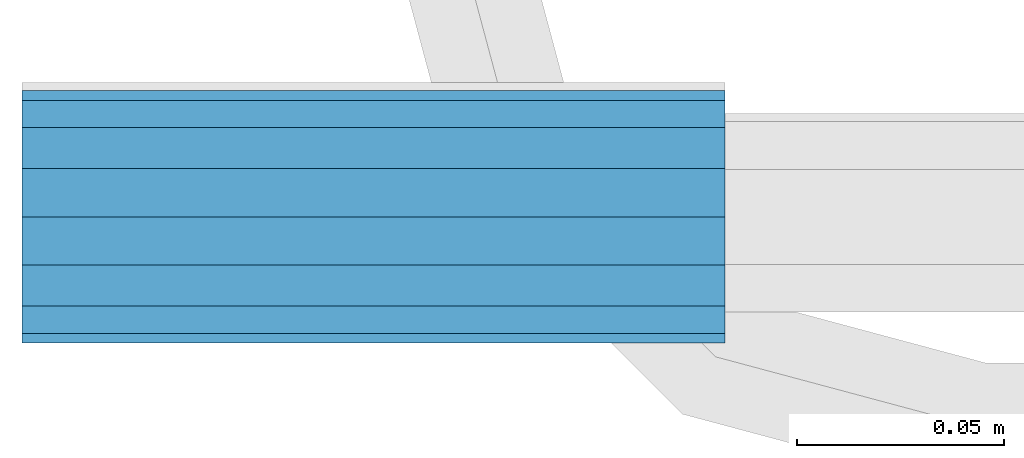
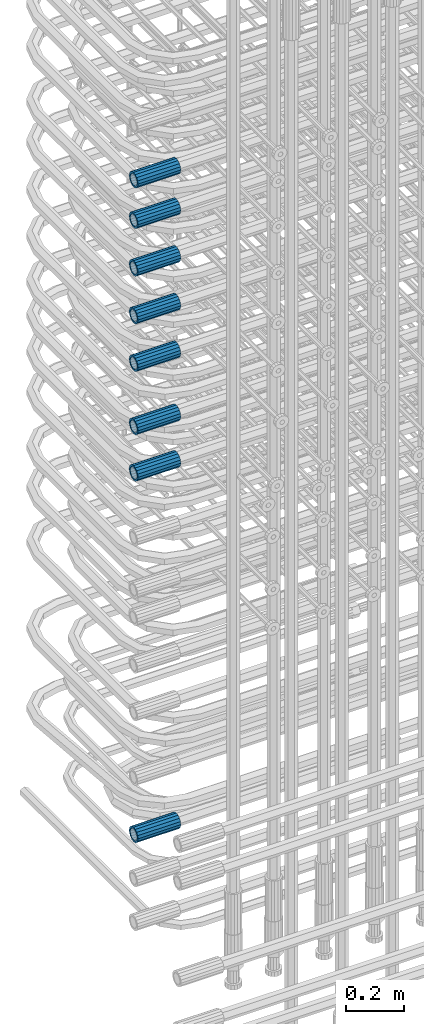
# One storey, part 30 of 177: 8 beams.
"""IFC2X3 building model written with IfcOpenShell, lengths in millimetres."""

import ifcopenshell
import ifcopenshell.guid

model = None  # the IFC model being written
_history = None  # IfcOwnerHistory: only IFC2X3 demands one
_inside = {}  # id of a spatial element -> (the spatial element, [elements in it])
_under = {}  # id of a project, library or spatial element -> (it, [spatial elements below it])
_declared = {}  # id of a project -> (the project, [libraries it declares])
_typed = {}  # id of a type object -> (the type object, [elements of that type])
_made_of = {}  # id of a material, layer set ... -> (it, [elements and type objects made of it])


def new_model(schema):
    """Start an empty IFC model of exactly this schema.

    Asked for "IFC4X3", IfcOpenShell would pick the latest addendum, in which some entities
    have other attributes; the version numbers below select the first issue.
    IFC2X3 requires an IfcOwnerHistory on every rooted entity: one is made here for all.
    """
    global model, _history
    if schema == "IFC4X3":
        model = ifcopenshell.file(schema_version=(4, 3, 0, 0))
    else:
        model = ifcopenshell.file(schema=schema)
    _inside.clear()
    _under.clear()
    _declared.clear()
    _typed.clear()
    _made_of.clear()
    _history = None
    if model.schema == "IFC2X3":
        org = make("IfcOrganization", Name="unknown")
        user = make(
            "IfcPersonAndOrganization",
            ThePerson=make("IfcPerson", FamilyName="unknown"),
            TheOrganization=org,
        )
        app = make(
            "IfcApplication",
            ApplicationDeveloper=org,
            Version="unknown",
            ApplicationFullName="unknown",
            ApplicationIdentifier="unknown",
        )
        _history = make(
            "IfcOwnerHistory",
            OwningUser=user,
            OwningApplication=app,
            ChangeAction="ADDED",
            CreationDate=0,
        )
    return model


def make(cls, **values):
    """One entity of the class cls with the attributes given. An attribute that is None is left unset."""
    return model.create_entity(
        cls, **{name: value for name, value in values.items() if value is not None}
    )


def rooted(cls, **values):
    """An entity with a GlobalId (a new one), such as an element, a storey or a relation."""
    return make(cls, GlobalId=ifcopenshell.guid.new(), OwnerHistory=_history, **values)


def si_unit(unit_type, name, prefix=None):
    """IfcSIUnit, for example si_unit("LENGTHUNIT", "METRE", prefix="MILLI")."""
    return make("IfcSIUnit", UnitType=unit_type, Prefix=prefix, Name=name)


def assignment(units):
    """IfcUnitAssignment: the units of a project."""
    return None if units is None else make("IfcUnitAssignment", Units=units)


def point(xyz):
    """IfcCartesianPoint."""
    return None if xyz is None else make("IfcCartesianPoint", Coordinates=xyz)


def direction(xyz):
    """IfcDirection."""
    return None if xyz is None else make("IfcDirection", DirectionRatios=xyz)


def frame(location, z_axis=None, x_axis=None):
    """IfcAxis2Placement3D, a coordinate frame: its origin and axes. An axis left out is left unset."""
    return make(
        "IfcAxis2Placement3D",
        Location=point(location),
        Axis=direction(z_axis),
        RefDirection=direction(x_axis),
    )


def origin_with_axes():
    """The frame at (0, 0, 0) with the z axis (0, 0, 1) and the x axis (1, 0, 0) written out."""
    return frame((0.0, 0.0, 0.0), z_axis=(0.0, 0.0, 1.0), x_axis=(1.0, 0.0, 0.0))


def place(relative_to, where):
    """IfcLocalPlacement: puts the frame where relative to a parent placement (None: the world)."""
    return make(
        "IfcLocalPlacement", PlacementRelTo=relative_to, RelativePlacement=where
    )


def context(
    kind, dimensions, precision=None, world=None, true_north=None, identifier=None
):
    """IfcGeometricRepresentationContext, for example the 3D "Model" context."""
    return make(
        "IfcGeometricRepresentationContext",
        ContextIdentifier=identifier,
        ContextType=kind,
        CoordinateSpaceDimension=dimensions,
        Precision=precision,
        WorldCoordinateSystem=world,
        TrueNorth=true_north,
    )


def subcontext(parent, identifier, kind, view, scale=None):
    """IfcGeometricRepresentationSubContext, for example "Body" below "Model"."""
    return make(
        "IfcGeometricRepresentationSubContext",
        ContextIdentifier=identifier,
        ContextType=kind,
        ParentContext=parent,
        TargetScale=scale,
        TargetView=view,
    )


def project(units=None, contexts=None):
    """IfcProject with its units and contexts."""
    return rooted(
        "IfcProject",
        Name="project",
        RepresentationContexts=contexts,
        UnitsInContext=assignment(units),
    )


def spatial(cls, under=None, at=None, **own):
    """A site, building, storey or space (cls), placed at a placement, below another one or the project."""
    s = rooted(cls, ObjectPlacement=at, **own)
    if under is not None:
        _under.setdefault(under.id(), (under, []))[1].append(s)
    return s


def faces_of(points, faces, orient=None, outer=None):
    """IfcFace entities. A face is a list of loops; a loop is a list of indices into points, from 0.

    orient and outer hold one flag for each loop. By default every Orientation is true, the
    first loop of a face is its IfcFaceOuterBound and the others are IfcFaceBound.
    """
    made = []
    for i, loops in enumerate(faces):
        bounds = []
        for j, loop in enumerate(loops):
            is_outer = j == 0 if outer is None else outer[i][j]
            bounds.append(
                make(
                    "IfcFaceOuterBound" if is_outer else "IfcFaceBound",
                    Bound=make("IfcPolyLoop", Polygon=[points[k] for k in loop]),
                    Orientation=True if orient is None else orient[i][j],
                )
            )
        made.append(make("IfcFace", Bounds=bounds))
    return made


def faceted_brep(points, faces, orient=None, outer=None, voids=None):
    """IfcFacetedBrep: a solid bounded by flat faces; with voids (closed shells), ...WithVoids."""
    shared = [point(p) for p in points]
    hull = make("IfcClosedShell", CfsFaces=faces_of(shared, faces, orient, outer))
    if voids is None:
        return make("IfcFacetedBrep", Outer=hull)
    return make(
        "IfcFacetedBrepWithVoids",
        Outer=hull,
        Voids=[
            make(cls, CfsFaces=faces_of(shared, fs, o, b)) for cls, fs, o, b in voids
        ],
    )


def shape(context_of_items, identifier, shape_type, items):
    """IfcShapeRepresentation: the items that make up one representation, for example the "Body"."""
    return make(
        "IfcShapeRepresentation",
        ContextOfItems=context_of_items,
        RepresentationIdentifier=identifier,
        RepresentationType=shape_type,
        Items=items,
    )


def material(Name=None, Category=None):
    """IfcMaterial."""
    return make("IfcMaterial", Name=Name, Category=Category)


def made_of(thing, what):
    """Note that an element or type object is made of a material, layer set ...; save() writes the relation."""
    if what is not None:
        _made_of.setdefault(what.id(), (what, []))[1].append(thing)
    return thing


def type_object(cls, material=None, **own):
    """A type object (cls), such as IfcWallType, which elements share."""
    return made_of(rooted(cls, **own), material)


def element(
    cls,
    number,
    at=None,
    inside=None,
    cuts=None,
    type_object=None,
    material=None,
    context=None,
    identifier="Body",
    shape_type=None,
    held_by="IfcProductDefinitionShape",
    body=None,
    shapes=None,
    **own,
):
    """One element of the class cls, such as IfcWall. Its Tag is "e" and its number.

    at: its placement. inside: the storey or other place that contains it. cuts: it is an
    opening in that element (IfcRelVoidsElement). A single representation is given by context,
    identifier, shape_type and body (its items); several are given by shapes. held_by: the class
    of the entity that holds the representations. save() writes the other relations.
    """
    e = rooted(cls, Tag="e%d" % number, ObjectPlacement=at, **own)
    if body is not None:
        shapes = [shape(context, identifier, shape_type, body)]
    if shapes is not None:
        e.Representation = make(held_by, Representations=shapes)
    if inside is not None:
        _inside.setdefault(inside.id(), (inside, []))[1].append(e)
    if cuts is not None:
        rooted(
            "IfcRelVoidsElement", RelatingBuildingElement=cuts, RelatedOpeningElement=e
        )
    if type_object is not None:
        _typed.setdefault(type_object.id(), (type_object, []))[1].append(e)
    return made_of(e, material)


def aggregate(whole, parts):
    """IfcRelAggregates: a whole, such as a stair, and the parts it consists of."""
    return rooted("IfcRelAggregates", RelatingObject=whole, RelatedObjects=parts)


def save(model, path):
    """Write the relations noted so far, then the file.

    IfcRelAggregates (storeys below a building ...), IfcRelContainedInSpatialStructure (elements
    in a storey), IfcRelDefinesByType, IfcRelAssociatesMaterial and IfcRelDeclares: one each for
    every whole, place, type object, material and project.
    """
    for whole, parts in _under.values():
        aggregate(whole, parts)
    for where, things in _inside.values():
        rooted(
            "IfcRelContainedInSpatialStructure",
            RelatedElements=things,
            RelatingStructure=where,
        )
    for kind, things in _typed.values():
        rooted("IfcRelDefinesByType", RelatedObjects=things, RelatingType=kind)
    for what, things in _made_of.values():
        rooted("IfcRelAssociatesMaterial", RelatedObjects=things, RelatingMaterial=what)
    for by, libraries in _declared.values():
        rooted("IfcRelDeclares", RelatingContext=by, RelatedDefinitions=libraries)
    model.write(path)


model = new_model("IFC2X3")

# Units and contexts
model_context_1 = context("Model", 3, precision=1e-05, world=origin_with_axes())
model_context_2 = context("Model", 3, precision=1e-05, world=origin_with_axes())
body_context = subcontext(model_context_2, "Body", "Model", "MODEL_VIEW")
ifc_project = project(units=[si_unit("LENGTHUNIT", "METRE", prefix="MILLI"), si_unit("AREAUNIT", "SQUARE_METRE"), si_unit("VOLUMEUNIT", "CUBIC_METRE"), si_unit("MASSUNIT", "GRAM", prefix="KILO"), si_unit("TIMEUNIT", "SECOND"), si_unit("PLANEANGLEUNIT", "RADIAN"), si_unit("SOLIDANGLEUNIT", "STERADIAN"), si_unit("THERMODYNAMICTEMPERATUREUNIT", "DEGREE_CELSIUS"), si_unit("LUMINOUSINTENSITYUNIT", "LUMEN")], contexts=[model_context_1])

# Site, building, storey
site_placement = place(None, origin_with_axes())
site = spatial("IfcSite", under=ifc_project, at=site_placement, CompositionType="ELEMENT")
building_placement = place(site_placement, origin_with_axes())
building = spatial("IfcBuilding", under=site, at=building_placement, Name="Undefined", CompositionType="ELEMENT")
storey_placement = place(building_placement, origin_with_axes())
storey = spatial("IfcBuildingStorey", under=building, at=storey_placement, Name="Undefined", CompositionType="ELEMENT", Elevation=0.0)

# Beams
ifc_material = material(Name="STEEL/S275")
beam_type = type_object("IfcBeamType", PredefinedType="NOTDEFINED")
beam_1_placement = place(storey_placement, frame((2029920.00847313, 6205398.93588033, 20848.9883264263), z_axis=(0.0, 0.0, 1.0), x_axis=(-1.0, 0.0, 0.0)))
element("IfcBeam", 1, at=beam_1_placement, inside=storey, type_object=beam_type, material=ifc_material, Name="AG40N", context=body_context, shape_type="Brep", body=[
    faceted_brep([(0.0, -23.5000000001164, -9.31322574615479e-10), (0.0, -21.7111690140155, 8.99306066054851), (170.0, -21.7111690140155, 8.99306066054851), (170.0, -23.5, 0.0), (0.0, -16.6170093578839, 16.6170093575493), (170.0, -16.6170093578839, 16.6170093575493), (0.0, -8.99306066057943, 21.7111690137535), (170.0, -8.99306066057943, 21.7111690137535), (0.0, 1.16415321826935e-10, 23.5), (170.0, 0.0, 23.5), (0.0, 8.99306066057943, 21.7111690137535), (170.0, 8.99306066057943, 21.7111690137535), (0.0, 16.6170093578839, 16.6170093575493), (170.0, 16.6170093578839, 16.6170093575493), (0.0, 21.7111690140155, 8.99306066054851), (170.0, 21.7111690140155, 8.99306066054851), (0.0, 23.5000000001164, -9.31322574615479e-10), (170.0, 23.5, 0.0), (0.0, 21.7111690140155, -8.99306066054851), (170.0, 21.7111690140155, -8.99306066054851), (0.0, 16.6170093578839, -16.6170093575493), (170.0, 16.6170093578839, -16.6170093575493), (0.0, 8.99306066057943, -21.7111690137535), (170.0, 8.99306066057943, -21.7111690137535), (0.0, 1.16415321826935e-10, -23.5000000009313), (170.0, 0.0, -23.5), (0.0, -8.99306066057943, -21.7111690137535), (170.0, -8.99306066057943, -21.7111690137535), (0.0, -16.6170093578839, -16.6170093575493), (170.0, -16.6170093578839, -16.6170093575493), (0.0, -21.7111690140155, -8.99306066054851), (170.0, -21.7111690140155, -8.99306066054851), (0.0, -30.5, 0.0), (0.0, -28.1783257415937, -11.6718446873128), (170.0, -28.1783257415937, -11.6718446873128), (170.0, -30.5, 0.0), (0.0, -21.5667568261888, -21.5667568258941), (170.0, -21.5667568261888, -21.5667568258941), (0.0, -11.6718446871346, -28.1783257415518), (170.0, -11.6718446871346, -28.1783257415518), (0.0, 0.0, -30.5), (170.0, 0.0, -30.5), (0.0, 11.6718446871346, -28.1783257415518), (170.0, 11.6718446871346, -28.1783257415518), (0.0, 21.5667568261888, -21.5667568258941), (170.0, 21.5667568261888, -21.5667568258941), (0.0, 28.1783257415937, -11.6718446873128), (170.0, 28.1783257415937, -11.6718446873128), (0.0, 30.5, 0.0), (170.0, 30.5, 0.0), (0.0, 28.1783257415937, 11.6718446873128), (170.0, 28.1783257415937, 11.6718446873128), (0.0, 21.5667568261888, 21.5667568258941), (170.0, 21.5667568261888, 21.5667568258941), (0.0, 11.6718446871346, 28.1783257415518), (170.0, 11.6718446871346, 28.1783257415518), (0.0, 0.0, 30.5), (170.0, 0.0, 30.5), (0.0, -11.6718446871346, 28.1783257415518), (170.0, -11.6718446871346, 28.1783257415518), (0.0, -21.5667568261888, 21.5667568258941), (170.0, -21.5667568261888, 21.5667568258941), (0.0, -28.1783257415937, 11.6718446873128), (170.0, -28.1783257415937, 11.6718446873128)], [[[0, 1, 2, 3]], [[1, 4, 5, 2]], [[4, 6, 7, 5]], [[6, 8, 9, 7]], [[8, 10, 11, 9]], [[10, 12, 13, 11]], [[12, 14, 15, 13]], [[14, 16, 17, 15]], [[16, 18, 19, 17]], [[18, 20, 21, 19]], [[20, 22, 23, 21]], [[22, 24, 25, 23]], [[24, 26, 27, 25]], [[26, 28, 29, 27]], [[28, 30, 31, 29]], [[30, 0, 3, 31]], [[32, 33, 34, 35]], [[33, 36, 37, 34]], [[36, 38, 39, 37]], [[38, 40, 41, 39]], [[40, 42, 43, 41]], [[42, 44, 45, 43]], [[44, 46, 47, 45]], [[46, 48, 49, 47]], [[48, 50, 51, 49]], [[50, 52, 53, 51]], [[52, 54, 55, 53]], [[54, 56, 57, 55]], [[56, 58, 59, 57]], [[58, 60, 61, 59]], [[60, 62, 63, 61]], [[62, 32, 35, 63]], [[37, 39, 41, 43, 45, 47, 49, 51, 53, 55, 57, 59, 61, 63, 35, 34], [5, 7, 9, 11, 13, 15, 17, 19, 21, 23, 25, 27, 29, 31, 3, 2]], [[62, 60, 58, 56, 54, 52, 50, 48, 46, 44, 42, 40, 38, 36, 33, 32], [30, 28, 26, 24, 22, 20, 18, 16, 14, 12, 10, 8, 6, 4, 1, 0]]]),
])
beam_2_placement = place(storey_placement, frame((2029920.00847313, 6205398.93588033, 19332.4883264263), z_axis=(0.0, 0.0, 1.0), x_axis=(-1.0, 0.0, 0.0)))
element("IfcBeam", 2, at=beam_2_placement, inside=storey, type_object=beam_type, material=ifc_material, Name="AG40N", context=body_context, shape_type="Brep", body=[
    faceted_brep([(0.0, -23.5000000001164, -9.31322574615479e-10), (0.0, -21.7111690140155, 8.99306066054851), (170.0, -21.7111690140155, 8.99306066054851), (170.0, -23.5, 0.0), (0.0, -16.6170093578839, 16.6170093575493), (170.0, -16.6170093578839, 16.6170093575493), (0.0, -8.99306066057943, 21.7111690137535), (170.0, -8.99306066057943, 21.7111690137535), (0.0, 1.16415321826935e-10, 23.5), (170.0, 0.0, 23.5), (0.0, 8.99306066057943, 21.7111690137535), (170.0, 8.99306066057943, 21.7111690137535), (0.0, 16.6170093578839, 16.6170093575493), (170.0, 16.6170093578839, 16.6170093575493), (0.0, 21.7111690140155, 8.99306066054851), (170.0, 21.7111690140155, 8.99306066054851), (0.0, 23.5000000001164, -9.31322574615479e-10), (170.0, 23.5, 0.0), (0.0, 21.7111690140155, -8.99306066054851), (170.0, 21.7111690140155, -8.99306066054851), (0.0, 16.6170093578839, -16.6170093575493), (170.0, 16.6170093578839, -16.6170093575493), (0.0, 8.99306066057943, -21.7111690137535), (170.0, 8.99306066057943, -21.7111690137535), (0.0, 1.16415321826935e-10, -23.5000000009313), (170.0, 0.0, -23.5), (0.0, -8.99306066057943, -21.7111690137535), (170.0, -8.99306066057943, -21.7111690137535), (0.0, -16.6170093578839, -16.6170093575493), (170.0, -16.6170093578839, -16.6170093575493), (0.0, -21.7111690140155, -8.99306066054851), (170.0, -21.7111690140155, -8.99306066054851), (0.0, -30.5, 0.0), (0.0, -28.1783257415937, -11.6718446873128), (170.0, -28.1783257415937, -11.6718446873128), (170.0, -30.5, 0.0), (0.0, -21.5667568261888, -21.5667568258941), (170.0, -21.5667568261888, -21.5667568258941), (0.0, -11.6718446871346, -28.1783257415518), (170.0, -11.6718446871346, -28.1783257415518), (0.0, 0.0, -30.5), (170.0, 0.0, -30.5), (0.0, 11.6718446871346, -28.1783257415518), (170.0, 11.6718446871346, -28.1783257415518), (0.0, 21.5667568261888, -21.5667568258941), (170.0, 21.5667568261888, -21.5667568258941), (0.0, 28.1783257415937, -11.6718446873128), (170.0, 28.1783257415937, -11.6718446873128), (0.0, 30.5, 0.0), (170.0, 30.5, 0.0), (0.0, 28.1783257415937, 11.6718446873128), (170.0, 28.1783257415937, 11.6718446873128), (0.0, 21.5667568261888, 21.5667568258941), (170.0, 21.5667568261888, 21.5667568258941), (0.0, 11.6718446871346, 28.1783257415518), (170.0, 11.6718446871346, 28.1783257415518), (0.0, 0.0, 30.5), (170.0, 0.0, 30.5), (0.0, -11.6718446871346, 28.1783257415518), (170.0, -11.6718446871346, 28.1783257415518), (0.0, -21.5667568261888, 21.5667568258941), (170.0, -21.5667568261888, 21.5667568258941), (0.0, -28.1783257415937, 11.6718446873128), (170.0, -28.1783257415937, 11.6718446873128)], [[[0, 1, 2, 3]], [[1, 4, 5, 2]], [[4, 6, 7, 5]], [[6, 8, 9, 7]], [[8, 10, 11, 9]], [[10, 12, 13, 11]], [[12, 14, 15, 13]], [[14, 16, 17, 15]], [[16, 18, 19, 17]], [[18, 20, 21, 19]], [[20, 22, 23, 21]], [[22, 24, 25, 23]], [[24, 26, 27, 25]], [[26, 28, 29, 27]], [[28, 30, 31, 29]], [[30, 0, 3, 31]], [[32, 33, 34, 35]], [[33, 36, 37, 34]], [[36, 38, 39, 37]], [[38, 40, 41, 39]], [[40, 42, 43, 41]], [[42, 44, 45, 43]], [[44, 46, 47, 45]], [[46, 48, 49, 47]], [[48, 50, 51, 49]], [[50, 52, 53, 51]], [[52, 54, 55, 53]], [[54, 56, 57, 55]], [[56, 58, 59, 57]], [[58, 60, 61, 59]], [[60, 62, 63, 61]], [[62, 32, 35, 63]], [[37, 39, 41, 43, 45, 47, 49, 51, 53, 55, 57, 59, 61, 63, 35, 34], [5, 7, 9, 11, 13, 15, 17, 19, 21, 23, 25, 27, 29, 31, 3, 2]], [[62, 60, 58, 56, 54, 52, 50, 48, 46, 44, 42, 40, 38, 36, 33, 32], [30, 28, 26, 24, 22, 20, 18, 16, 14, 12, 10, 8, 6, 4, 1, 0]]]),
])
beam_3_placement = place(storey_placement, frame((2029920.00847313, 6205398.93588033, 21043.9883264263), z_axis=(0.0, 0.0, 1.0), x_axis=(-1.0, 0.0, 0.0)))
element("IfcBeam", 3, at=beam_3_placement, inside=storey, type_object=beam_type, material=ifc_material, Name="AG40N", context=body_context, shape_type="Brep", body=[
    faceted_brep([(0.0, -23.5000000001164, -9.31322574615479e-10), (0.0, -21.7111690140155, 8.99306066054851), (170.0, -21.7111690140155, 8.99306066054851), (170.0, -23.5, 0.0), (0.0, -16.6170093578839, 16.6170093575493), (170.0, -16.6170093578839, 16.6170093575493), (0.0, -8.99306066057943, 21.7111690137535), (170.0, -8.99306066057943, 21.7111690137535), (0.0, 1.16415321826935e-10, 23.5), (170.0, 0.0, 23.5), (0.0, 8.99306066057943, 21.7111690137535), (170.0, 8.99306066057943, 21.7111690137535), (0.0, 16.6170093578839, 16.6170093575493), (170.0, 16.6170093578839, 16.6170093575493), (0.0, 21.7111690140155, 8.99306066054851), (170.0, 21.7111690140155, 8.99306066054851), (0.0, 23.5000000001164, -9.31322574615479e-10), (170.0, 23.5, 0.0), (0.0, 21.7111690140155, -8.99306066054851), (170.0, 21.7111690140155, -8.99306066054851), (0.0, 16.6170093578839, -16.6170093575493), (170.0, 16.6170093578839, -16.6170093575493), (0.0, 8.99306066057943, -21.7111690137535), (170.0, 8.99306066057943, -21.7111690137535), (0.0, 1.16415321826935e-10, -23.5000000009313), (170.0, 0.0, -23.5), (0.0, -8.99306066057943, -21.7111690137535), (170.0, -8.99306066057943, -21.7111690137535), (0.0, -16.6170093578839, -16.6170093575493), (170.0, -16.6170093578839, -16.6170093575493), (0.0, -21.7111690140155, -8.99306066054851), (170.0, -21.7111690140155, -8.99306066054851), (0.0, -30.5, 0.0), (0.0, -28.1783257415937, -11.6718446873128), (170.0, -28.1783257415937, -11.6718446873128), (170.0, -30.5, 0.0), (0.0, -21.5667568261888, -21.5667568258941), (170.0, -21.5667568261888, -21.5667568258941), (0.0, -11.6718446871346, -28.1783257415518), (170.0, -11.6718446871346, -28.1783257415518), (0.0, 0.0, -30.5), (170.0, 0.0, -30.5), (0.0, 11.6718446871346, -28.1783257415518), (170.0, 11.6718446871346, -28.1783257415518), (0.0, 21.5667568261888, -21.5667568258941), (170.0, 21.5667568261888, -21.5667568258941), (0.0, 28.1783257415937, -11.6718446873128), (170.0, 28.1783257415937, -11.6718446873128), (0.0, 30.5, 0.0), (170.0, 30.5, 0.0), (0.0, 28.1783257415937, 11.6718446873128), (170.0, 28.1783257415937, 11.6718446873128), (0.0, 21.5667568261888, 21.5667568258941), (170.0, 21.5667568261888, 21.5667568258941), (0.0, 11.6718446871346, 28.1783257415518), (170.0, 11.6718446871346, 28.1783257415518), (0.0, 0.0, 30.5), (170.0, 0.0, 30.5), (0.0, -11.6718446871346, 28.1783257415518), (170.0, -11.6718446871346, 28.1783257415518), (0.0, -21.5667568261888, 21.5667568258941), (170.0, -21.5667568261888, 21.5667568258941), (0.0, -28.1783257415937, 11.6718446873128), (170.0, -28.1783257415937, 11.6718446873128)], [[[0, 1, 2, 3]], [[1, 4, 5, 2]], [[4, 6, 7, 5]], [[6, 8, 9, 7]], [[8, 10, 11, 9]], [[10, 12, 13, 11]], [[12, 14, 15, 13]], [[14, 16, 17, 15]], [[16, 18, 19, 17]], [[18, 20, 21, 19]], [[20, 22, 23, 21]], [[22, 24, 25, 23]], [[24, 26, 27, 25]], [[26, 28, 29, 27]], [[28, 30, 31, 29]], [[30, 0, 3, 31]], [[32, 33, 34, 35]], [[33, 36, 37, 34]], [[36, 38, 39, 37]], [[38, 40, 41, 39]], [[40, 42, 43, 41]], [[42, 44, 45, 43]], [[44, 46, 47, 45]], [[46, 48, 49, 47]], [[48, 50, 51, 49]], [[50, 52, 53, 51]], [[52, 54, 55, 53]], [[54, 56, 57, 55]], [[56, 58, 59, 57]], [[58, 60, 61, 59]], [[60, 62, 63, 61]], [[62, 32, 35, 63]], [[37, 39, 41, 43, 45, 47, 49, 51, 53, 55, 57, 59, 61, 63, 35, 34], [5, 7, 9, 11, 13, 15, 17, 19, 21, 23, 25, 27, 29, 31, 3, 2]], [[62, 60, 58, 56, 54, 52, 50, 48, 46, 44, 42, 40, 38, 36, 33, 32], [30, 28, 26, 24, 22, 20, 18, 16, 14, 12, 10, 8, 6, 4, 1, 0]]]),
])
beam_4_placement = place(storey_placement, frame((2029920.00847313, 6205398.93588033, 21308.9883264263), z_axis=(0.0, 0.0, 1.0), x_axis=(-1.0, 0.0, 0.0)))
element("IfcBeam", 4, at=beam_4_placement, inside=storey, type_object=beam_type, material=ifc_material, Name="AG40N", context=body_context, shape_type="Brep", body=[
    faceted_brep([(0.0, -23.5000000001164, -9.31322574615479e-10), (0.0, -21.7111690140155, 8.99306066054851), (170.0, -21.7111690140155, 8.99306066054851), (170.0, -23.5, 0.0), (0.0, -16.6170093578839, 16.6170093575493), (170.0, -16.6170093578839, 16.6170093575493), (0.0, -8.99306066057943, 21.7111690137535), (170.0, -8.99306066057943, 21.7111690137535), (0.0, 1.16415321826935e-10, 23.5), (170.0, 0.0, 23.5), (0.0, 8.99306066057943, 21.7111690137535), (170.0, 8.99306066057943, 21.7111690137535), (0.0, 16.6170093578839, 16.6170093575493), (170.0, 16.6170093578839, 16.6170093575493), (0.0, 21.7111690140155, 8.99306066054851), (170.0, 21.7111690140155, 8.99306066054851), (0.0, 23.5000000001164, -9.31322574615479e-10), (170.0, 23.5, 0.0), (0.0, 21.7111690140155, -8.99306066054851), (170.0, 21.7111690140155, -8.99306066054851), (0.0, 16.6170093578839, -16.6170093575493), (170.0, 16.6170093578839, -16.6170093575493), (0.0, 8.99306066057943, -21.7111690137535), (170.0, 8.99306066057943, -21.7111690137535), (0.0, 1.16415321826935e-10, -23.5000000009313), (170.0, 0.0, -23.5), (0.0, -8.99306066057943, -21.7111690137535), (170.0, -8.99306066057943, -21.7111690137535), (0.0, -16.6170093578839, -16.6170093575493), (170.0, -16.6170093578839, -16.6170093575493), (0.0, -21.7111690140155, -8.99306066054851), (170.0, -21.7111690140155, -8.99306066054851), (0.0, -30.5, 0.0), (0.0, -28.1783257415937, -11.6718446873128), (170.0, -28.1783257415937, -11.6718446873128), (170.0, -30.5, 0.0), (0.0, -21.5667568261888, -21.5667568258941), (170.0, -21.5667568261888, -21.5667568258941), (0.0, -11.6718446871346, -28.1783257415518), (170.0, -11.6718446871346, -28.1783257415518), (0.0, 0.0, -30.5), (170.0, 0.0, -30.5), (0.0, 11.6718446871346, -28.1783257415518), (170.0, 11.6718446871346, -28.1783257415518), (0.0, 21.5667568261888, -21.5667568258941), (170.0, 21.5667568261888, -21.5667568258941), (0.0, 28.1783257415937, -11.6718446873128), (170.0, 28.1783257415937, -11.6718446873128), (0.0, 30.5, 0.0), (170.0, 30.5, 0.0), (0.0, 28.1783257415937, 11.6718446873128), (170.0, 28.1783257415937, 11.6718446873128), (0.0, 21.5667568261888, 21.5667568258941), (170.0, 21.5667568261888, 21.5667568258941), (0.0, 11.6718446871346, 28.1783257415518), (170.0, 11.6718446871346, 28.1783257415518), (0.0, 0.0, 30.5), (170.0, 0.0, 30.5), (0.0, -11.6718446871346, 28.1783257415518), (170.0, -11.6718446871346, 28.1783257415518), (0.0, -21.5667568261888, 21.5667568258941), (170.0, -21.5667568261888, 21.5667568258941), (0.0, -28.1783257415937, 11.6718446873128), (170.0, -28.1783257415937, 11.6718446873128)], [[[0, 1, 2, 3]], [[1, 4, 5, 2]], [[4, 6, 7, 5]], [[6, 8, 9, 7]], [[8, 10, 11, 9]], [[10, 12, 13, 11]], [[12, 14, 15, 13]], [[14, 16, 17, 15]], [[16, 18, 19, 17]], [[18, 20, 21, 19]], [[20, 22, 23, 21]], [[22, 24, 25, 23]], [[24, 26, 27, 25]], [[26, 28, 29, 27]], [[28, 30, 31, 29]], [[30, 0, 3, 31]], [[32, 33, 34, 35]], [[33, 36, 37, 34]], [[36, 38, 39, 37]], [[38, 40, 41, 39]], [[40, 42, 43, 41]], [[42, 44, 45, 43]], [[44, 46, 47, 45]], [[46, 48, 49, 47]], [[48, 50, 51, 49]], [[50, 52, 53, 51]], [[52, 54, 55, 53]], [[54, 56, 57, 55]], [[56, 58, 59, 57]], [[58, 60, 61, 59]], [[60, 62, 63, 61]], [[62, 32, 35, 63]], [[37, 39, 41, 43, 45, 47, 49, 51, 53, 55, 57, 59, 61, 63, 35, 34], [5, 7, 9, 11, 13, 15, 17, 19, 21, 23, 25, 27, 29, 31, 3, 2]], [[62, 60, 58, 56, 54, 52, 50, 48, 46, 44, 42, 40, 38, 36, 33, 32], [30, 28, 26, 24, 22, 20, 18, 16, 14, 12, 10, 8, 6, 4, 1, 0]]]),
])
beam_5_placement = place(storey_placement, frame((2029920.00847313, 6205398.93588033, 21508.9883264263), z_axis=(0.0, 0.0, 1.0), x_axis=(-1.0, 0.0, 0.0)))
element("IfcBeam", 5, at=beam_5_placement, inside=storey, type_object=beam_type, material=ifc_material, Name="AG40N", context=body_context, shape_type="Brep", body=[
    faceted_brep([(0.0, -23.5000000001164, -9.31322574615479e-10), (0.0, -21.7111690140155, 8.99306066054851), (170.0, -21.7111690140155, 8.99306066054851), (170.0, -23.5, 0.0), (0.0, -16.6170093578839, 16.6170093575493), (170.0, -16.6170093578839, 16.6170093575493), (0.0, -8.99306066057943, 21.7111690137535), (170.0, -8.99306066057943, 21.7111690137535), (0.0, 1.16415321826935e-10, 23.5), (170.0, 0.0, 23.5), (0.0, 8.99306066057943, 21.7111690137535), (170.0, 8.99306066057943, 21.7111690137535), (0.0, 16.6170093578839, 16.6170093575493), (170.0, 16.6170093578839, 16.6170093575493), (0.0, 21.7111690140155, 8.99306066054851), (170.0, 21.7111690140155, 8.99306066054851), (0.0, 23.5000000001164, -9.31322574615479e-10), (170.0, 23.5, 0.0), (0.0, 21.7111690140155, -8.99306066054851), (170.0, 21.7111690140155, -8.99306066054851), (0.0, 16.6170093578839, -16.6170093575493), (170.0, 16.6170093578839, -16.6170093575493), (0.0, 8.99306066057943, -21.7111690137535), (170.0, 8.99306066057943, -21.7111690137535), (0.0, 1.16415321826935e-10, -23.5000000009313), (170.0, 0.0, -23.5), (0.0, -8.99306066057943, -21.7111690137535), (170.0, -8.99306066057943, -21.7111690137535), (0.0, -16.6170093578839, -16.6170093575493), (170.0, -16.6170093578839, -16.6170093575493), (0.0, -21.7111690140155, -8.99306066054851), (170.0, -21.7111690140155, -8.99306066054851), (0.0, -30.5, 0.0), (0.0, -28.1783257415937, -11.6718446873128), (170.0, -28.1783257415937, -11.6718446873128), (170.0, -30.5, 0.0), (0.0, -21.5667568261888, -21.5667568258941), (170.0, -21.5667568261888, -21.5667568258941), (0.0, -11.6718446871346, -28.1783257415518), (170.0, -11.6718446871346, -28.1783257415518), (0.0, 0.0, -30.5), (170.0, 0.0, -30.5), (0.0, 11.6718446871346, -28.1783257415518), (170.0, 11.6718446871346, -28.1783257415518), (0.0, 21.5667568261888, -21.5667568258941), (170.0, 21.5667568261888, -21.5667568258941), (0.0, 28.1783257415937, -11.6718446873128), (170.0, 28.1783257415937, -11.6718446873128), (0.0, 30.5, 0.0), (170.0, 30.5, 0.0), (0.0, 28.1783257415937, 11.6718446873128), (170.0, 28.1783257415937, 11.6718446873128), (0.0, 21.5667568261888, 21.5667568258941), (170.0, 21.5667568261888, 21.5667568258941), (0.0, 11.6718446871346, 28.1783257415518), (170.0, 11.6718446871346, 28.1783257415518), (0.0, 0.0, 30.5), (170.0, 0.0, 30.5), (0.0, -11.6718446871346, 28.1783257415518), (170.0, -11.6718446871346, 28.1783257415518), (0.0, -21.5667568261888, 21.5667568258941), (170.0, -21.5667568261888, 21.5667568258941), (0.0, -28.1783257415937, 11.6718446873128), (170.0, -28.1783257415937, 11.6718446873128)], [[[0, 1, 2, 3]], [[1, 4, 5, 2]], [[4, 6, 7, 5]], [[6, 8, 9, 7]], [[8, 10, 11, 9]], [[10, 12, 13, 11]], [[12, 14, 15, 13]], [[14, 16, 17, 15]], [[16, 18, 19, 17]], [[18, 20, 21, 19]], [[20, 22, 23, 21]], [[22, 24, 25, 23]], [[24, 26, 27, 25]], [[26, 28, 29, 27]], [[28, 30, 31, 29]], [[30, 0, 3, 31]], [[32, 33, 34, 35]], [[33, 36, 37, 34]], [[36, 38, 39, 37]], [[38, 40, 41, 39]], [[40, 42, 43, 41]], [[42, 44, 45, 43]], [[44, 46, 47, 45]], [[46, 48, 49, 47]], [[48, 50, 51, 49]], [[50, 52, 53, 51]], [[52, 54, 55, 53]], [[54, 56, 57, 55]], [[56, 58, 59, 57]], [[58, 60, 61, 59]], [[60, 62, 63, 61]], [[62, 32, 35, 63]], [[37, 39, 41, 43, 45, 47, 49, 51, 53, 55, 57, 59, 61, 63, 35, 34], [5, 7, 9, 11, 13, 15, 17, 19, 21, 23, 25, 27, 29, 31, 3, 2]], [[62, 60, 58, 56, 54, 52, 50, 48, 46, 44, 42, 40, 38, 36, 33, 32], [30, 28, 26, 24, 22, 20, 18, 16, 14, 12, 10, 8, 6, 4, 1, 0]]]),
])
beam_6_placement = place(storey_placement, frame((2029920.00847313, 6205398.93588033, 21708.9883264263), z_axis=(0.0, 0.0, 1.0), x_axis=(-1.0, 0.0, 0.0)))
element("IfcBeam", 6, at=beam_6_placement, inside=storey, type_object=beam_type, material=ifc_material, Name="AG40N", context=body_context, shape_type="Brep", body=[
    faceted_brep([(0.0, -23.5000000001164, -9.31322574615479e-10), (0.0, -21.7111690140155, 8.99306066054851), (170.0, -21.7111690140155, 8.99306066054851), (170.0, -23.5, 0.0), (0.0, -16.6170093578839, 16.6170093575493), (170.0, -16.6170093578839, 16.6170093575493), (0.0, -8.99306066057943, 21.7111690137535), (170.0, -8.99306066057943, 21.7111690137535), (0.0, 1.16415321826935e-10, 23.5), (170.0, 0.0, 23.5), (0.0, 8.99306066057943, 21.7111690137535), (170.0, 8.99306066057943, 21.7111690137535), (0.0, 16.6170093578839, 16.6170093575493), (170.0, 16.6170093578839, 16.6170093575493), (0.0, 21.7111690140155, 8.99306066054851), (170.0, 21.7111690140155, 8.99306066054851), (0.0, 23.5000000001164, -9.31322574615479e-10), (170.0, 23.5, 0.0), (0.0, 21.7111690140155, -8.99306066054851), (170.0, 21.7111690140155, -8.99306066054851), (0.0, 16.6170093578839, -16.6170093575493), (170.0, 16.6170093578839, -16.6170093575493), (0.0, 8.99306066057943, -21.7111690137535), (170.0, 8.99306066057943, -21.7111690137535), (0.0, 1.16415321826935e-10, -23.5000000009313), (170.0, 0.0, -23.5), (0.0, -8.99306066057943, -21.7111690137535), (170.0, -8.99306066057943, -21.7111690137535), (0.0, -16.6170093578839, -16.6170093575493), (170.0, -16.6170093578839, -16.6170093575493), (0.0, -21.7111690140155, -8.99306066054851), (170.0, -21.7111690140155, -8.99306066054851), (0.0, -30.5, 0.0), (0.0, -28.1783257415937, -11.6718446873128), (170.0, -28.1783257415937, -11.6718446873128), (170.0, -30.5, 0.0), (0.0, -21.5667568261888, -21.5667568258941), (170.0, -21.5667568261888, -21.5667568258941), (0.0, -11.6718446871346, -28.1783257415518), (170.0, -11.6718446871346, -28.1783257415518), (0.0, 0.0, -30.5), (170.0, 0.0, -30.5), (0.0, 11.6718446871346, -28.1783257415518), (170.0, 11.6718446871346, -28.1783257415518), (0.0, 21.5667568261888, -21.5667568258941), (170.0, 21.5667568261888, -21.5667568258941), (0.0, 28.1783257415937, -11.6718446873128), (170.0, 28.1783257415937, -11.6718446873128), (0.0, 30.5, 0.0), (170.0, 30.5, 0.0), (0.0, 28.1783257415937, 11.6718446873128), (170.0, 28.1783257415937, 11.6718446873128), (0.0, 21.5667568261888, 21.5667568258941), (170.0, 21.5667568261888, 21.5667568258941), (0.0, 11.6718446871346, 28.1783257415518), (170.0, 11.6718446871346, 28.1783257415518), (0.0, 0.0, 30.5), (170.0, 0.0, 30.5), (0.0, -11.6718446871346, 28.1783257415518), (170.0, -11.6718446871346, 28.1783257415518), (0.0, -21.5667568261888, 21.5667568258941), (170.0, -21.5667568261888, 21.5667568258941), (0.0, -28.1783257415937, 11.6718446873128), (170.0, -28.1783257415937, 11.6718446873128)], [[[0, 1, 2, 3]], [[1, 4, 5, 2]], [[4, 6, 7, 5]], [[6, 8, 9, 7]], [[8, 10, 11, 9]], [[10, 12, 13, 11]], [[12, 14, 15, 13]], [[14, 16, 17, 15]], [[16, 18, 19, 17]], [[18, 20, 21, 19]], [[20, 22, 23, 21]], [[22, 24, 25, 23]], [[24, 26, 27, 25]], [[26, 28, 29, 27]], [[28, 30, 31, 29]], [[30, 0, 3, 31]], [[32, 33, 34, 35]], [[33, 36, 37, 34]], [[36, 38, 39, 37]], [[38, 40, 41, 39]], [[40, 42, 43, 41]], [[42, 44, 45, 43]], [[44, 46, 47, 45]], [[46, 48, 49, 47]], [[48, 50, 51, 49]], [[50, 52, 53, 51]], [[52, 54, 55, 53]], [[54, 56, 57, 55]], [[56, 58, 59, 57]], [[58, 60, 61, 59]], [[60, 62, 63, 61]], [[62, 32, 35, 63]], [[37, 39, 41, 43, 45, 47, 49, 51, 53, 55, 57, 59, 61, 63, 35, 34], [5, 7, 9, 11, 13, 15, 17, 19, 21, 23, 25, 27, 29, 31, 3, 2]], [[62, 60, 58, 56, 54, 52, 50, 48, 46, 44, 42, 40, 38, 36, 33, 32], [30, 28, 26, 24, 22, 20, 18, 16, 14, 12, 10, 8, 6, 4, 1, 0]]]),
])
beam_7_placement = place(storey_placement, frame((2029920.00847313, 6205398.93588033, 21908.9883264263), z_axis=(0.0, 0.0, 1.0), x_axis=(-1.0, 0.0, 0.0)))
element("IfcBeam", 7, at=beam_7_placement, inside=storey, type_object=beam_type, material=ifc_material, Name="AG40N", context=body_context, shape_type="Brep", body=[
    faceted_brep([(0.0, -23.5000000001164, -9.31322574615479e-10), (0.0, -21.7111690140155, 8.99306066054851), (170.0, -21.7111690140155, 8.99306066054851), (170.0, -23.5, 0.0), (0.0, -16.6170093578839, 16.6170093575493), (170.0, -16.6170093578839, 16.6170093575493), (0.0, -8.99306066057943, 21.7111690137535), (170.0, -8.99306066057943, 21.7111690137535), (0.0, 1.16415321826935e-10, 23.5), (170.0, 0.0, 23.5), (0.0, 8.99306066057943, 21.7111690137535), (170.0, 8.99306066057943, 21.7111690137535), (0.0, 16.6170093578839, 16.6170093575493), (170.0, 16.6170093578839, 16.6170093575493), (0.0, 21.7111690140155, 8.99306066054851), (170.0, 21.7111690140155, 8.99306066054851), (0.0, 23.5000000001164, -9.31322574615479e-10), (170.0, 23.5, 0.0), (0.0, 21.7111690140155, -8.99306066054851), (170.0, 21.7111690140155, -8.99306066054851), (0.0, 16.6170093578839, -16.6170093575493), (170.0, 16.6170093578839, -16.6170093575493), (0.0, 8.99306066057943, -21.7111690137535), (170.0, 8.99306066057943, -21.7111690137535), (0.0, 1.16415321826935e-10, -23.5000000009313), (170.0, 0.0, -23.5), (0.0, -8.99306066057943, -21.7111690137535), (170.0, -8.99306066057943, -21.7111690137535), (0.0, -16.6170093578839, -16.6170093575493), (170.0, -16.6170093578839, -16.6170093575493), (0.0, -21.7111690140155, -8.99306066054851), (170.0, -21.7111690140155, -8.99306066054851), (0.0, -30.5, 0.0), (0.0, -28.1783257415937, -11.6718446873128), (170.0, -28.1783257415937, -11.6718446873128), (170.0, -30.5, 0.0), (0.0, -21.5667568261888, -21.5667568258941), (170.0, -21.5667568261888, -21.5667568258941), (0.0, -11.6718446871346, -28.1783257415518), (170.0, -11.6718446871346, -28.1783257415518), (0.0, 0.0, -30.5), (170.0, 0.0, -30.5), (0.0, 11.6718446871346, -28.1783257415518), (170.0, 11.6718446871346, -28.1783257415518), (0.0, 21.5667568261888, -21.5667568258941), (170.0, 21.5667568261888, -21.5667568258941), (0.0, 28.1783257415937, -11.6718446873128), (170.0, 28.1783257415937, -11.6718446873128), (0.0, 30.5, 0.0), (170.0, 30.5, 0.0), (0.0, 28.1783257415937, 11.6718446873128), (170.0, 28.1783257415937, 11.6718446873128), (0.0, 21.5667568261888, 21.5667568258941), (170.0, 21.5667568261888, 21.5667568258941), (0.0, 11.6718446871346, 28.1783257415518), (170.0, 11.6718446871346, 28.1783257415518), (0.0, 0.0, 30.5), (170.0, 0.0, 30.5), (0.0, -11.6718446871346, 28.1783257415518), (170.0, -11.6718446871346, 28.1783257415518), (0.0, -21.5667568261888, 21.5667568258941), (170.0, -21.5667568261888, 21.5667568258941), (0.0, -28.1783257415937, 11.6718446873128), (170.0, -28.1783257415937, 11.6718446873128)], [[[0, 1, 2, 3]], [[1, 4, 5, 2]], [[4, 6, 7, 5]], [[6, 8, 9, 7]], [[8, 10, 11, 9]], [[10, 12, 13, 11]], [[12, 14, 15, 13]], [[14, 16, 17, 15]], [[16, 18, 19, 17]], [[18, 20, 21, 19]], [[20, 22, 23, 21]], [[22, 24, 25, 23]], [[24, 26, 27, 25]], [[26, 28, 29, 27]], [[28, 30, 31, 29]], [[30, 0, 3, 31]], [[32, 33, 34, 35]], [[33, 36, 37, 34]], [[36, 38, 39, 37]], [[38, 40, 41, 39]], [[40, 42, 43, 41]], [[42, 44, 45, 43]], [[44, 46, 47, 45]], [[46, 48, 49, 47]], [[48, 50, 51, 49]], [[50, 52, 53, 51]], [[52, 54, 55, 53]], [[54, 56, 57, 55]], [[56, 58, 59, 57]], [[58, 60, 61, 59]], [[60, 62, 63, 61]], [[62, 32, 35, 63]], [[37, 39, 41, 43, 45, 47, 49, 51, 53, 55, 57, 59, 61, 63, 35, 34], [5, 7, 9, 11, 13, 15, 17, 19, 21, 23, 25, 27, 29, 31, 3, 2]], [[62, 60, 58, 56, 54, 52, 50, 48, 46, 44, 42, 40, 38, 36, 33, 32], [30, 28, 26, 24, 22, 20, 18, 16, 14, 12, 10, 8, 6, 4, 1, 0]]]),
])
beam_8_placement = place(storey_placement, frame((2029920.00847313, 6205398.93588033, 22078.9883264263), z_axis=(0.0, 0.0, 1.0), x_axis=(-1.0, 0.0, 0.0)))
element("IfcBeam", 8, at=beam_8_placement, inside=storey, type_object=beam_type, material=ifc_material, Name="AG40N", context=body_context, shape_type="Brep", body=[
    faceted_brep([(0.0, -23.5000000001164, -9.31322574615479e-10), (0.0, -21.7111690140155, 8.99306066054851), (170.0, -21.7111690140155, 8.99306066054851), (170.0, -23.5, 0.0), (0.0, -16.6170093578839, 16.6170093575493), (170.0, -16.6170093578839, 16.6170093575493), (0.0, -8.99306066057943, 21.7111690137535), (170.0, -8.99306066057943, 21.7111690137535), (0.0, 1.16415321826935e-10, 23.5), (170.0, 0.0, 23.5), (0.0, 8.99306066057943, 21.7111690137535), (170.0, 8.99306066057943, 21.7111690137535), (0.0, 16.6170093578839, 16.6170093575493), (170.0, 16.6170093578839, 16.6170093575493), (0.0, 21.7111690140155, 8.99306066054851), (170.0, 21.7111690140155, 8.99306066054851), (0.0, 23.5000000001164, -9.31322574615479e-10), (170.0, 23.5, 0.0), (0.0, 21.7111690140155, -8.99306066054851), (170.0, 21.7111690140155, -8.99306066054851), (0.0, 16.6170093578839, -16.6170093575493), (170.0, 16.6170093578839, -16.6170093575493), (0.0, 8.99306066057943, -21.7111690137535), (170.0, 8.99306066057943, -21.7111690137535), (0.0, 1.16415321826935e-10, -23.5000000009313), (170.0, 0.0, -23.5), (0.0, -8.99306066057943, -21.7111690137535), (170.0, -8.99306066057943, -21.7111690137535), (0.0, -16.6170093578839, -16.6170093575493), (170.0, -16.6170093578839, -16.6170093575493), (0.0, -21.7111690140155, -8.99306066054851), (170.0, -21.7111690140155, -8.99306066054851), (0.0, -30.5, 0.0), (0.0, -28.1783257415937, -11.6718446873128), (170.0, -28.1783257415937, -11.6718446873128), (170.0, -30.5, 0.0), (0.0, -21.5667568261888, -21.5667568258941), (170.0, -21.5667568261888, -21.5667568258941), (0.0, -11.6718446871346, -28.1783257415518), (170.0, -11.6718446871346, -28.1783257415518), (0.0, 0.0, -30.5), (170.0, 0.0, -30.5), (0.0, 11.6718446871346, -28.1783257415518), (170.0, 11.6718446871346, -28.1783257415518), (0.0, 21.5667568261888, -21.5667568258941), (170.0, 21.5667568261888, -21.5667568258941), (0.0, 28.1783257415937, -11.6718446873128), (170.0, 28.1783257415937, -11.6718446873128), (0.0, 30.5, 0.0), (170.0, 30.5, 0.0), (0.0, 28.1783257415937, 11.6718446873128), (170.0, 28.1783257415937, 11.6718446873128), (0.0, 21.5667568261888, 21.5667568258941), (170.0, 21.5667568261888, 21.5667568258941), (0.0, 11.6718446871346, 28.1783257415518), (170.0, 11.6718446871346, 28.1783257415518), (0.0, 0.0, 30.5), (170.0, 0.0, 30.5), (0.0, -11.6718446871346, 28.1783257415518), (170.0, -11.6718446871346, 28.1783257415518), (0.0, -21.5667568261888, 21.5667568258941), (170.0, -21.5667568261888, 21.5667568258941), (0.0, -28.1783257415937, 11.6718446873128), (170.0, -28.1783257415937, 11.6718446873128)], [[[0, 1, 2, 3]], [[1, 4, 5, 2]], [[4, 6, 7, 5]], [[6, 8, 9, 7]], [[8, 10, 11, 9]], [[10, 12, 13, 11]], [[12, 14, 15, 13]], [[14, 16, 17, 15]], [[16, 18, 19, 17]], [[18, 20, 21, 19]], [[20, 22, 23, 21]], [[22, 24, 25, 23]], [[24, 26, 27, 25]], [[26, 28, 29, 27]], [[28, 30, 31, 29]], [[30, 0, 3, 31]], [[32, 33, 34, 35]], [[33, 36, 37, 34]], [[36, 38, 39, 37]], [[38, 40, 41, 39]], [[40, 42, 43, 41]], [[42, 44, 45, 43]], [[44, 46, 47, 45]], [[46, 48, 49, 47]], [[48, 50, 51, 49]], [[50, 52, 53, 51]], [[52, 54, 55, 53]], [[54, 56, 57, 55]], [[56, 58, 59, 57]], [[58, 60, 61, 59]], [[60, 62, 63, 61]], [[62, 32, 35, 63]], [[37, 39, 41, 43, 45, 47, 49, 51, 53, 55, 57, 59, 61, 63, 35, 34], [5, 7, 9, 11, 13, 15, 17, 19, 21, 23, 25, 27, 29, 31, 3, 2]], [[62, 60, 58, 56, 54, 52, 50, 48, 46, 44, 42, 40, 38, 36, 33, 32], [30, 28, 26, 24, 22, 20, 18, 16, 14, 12, 10, 8, 6, 4, 1, 0]]]),
])

save(model, "model.ifc")
